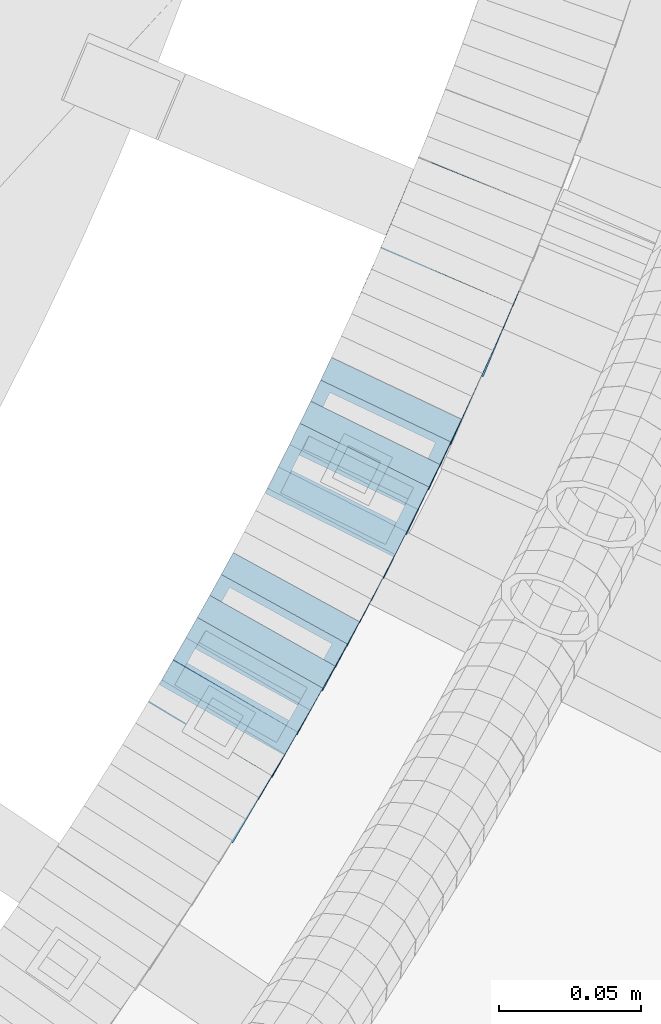
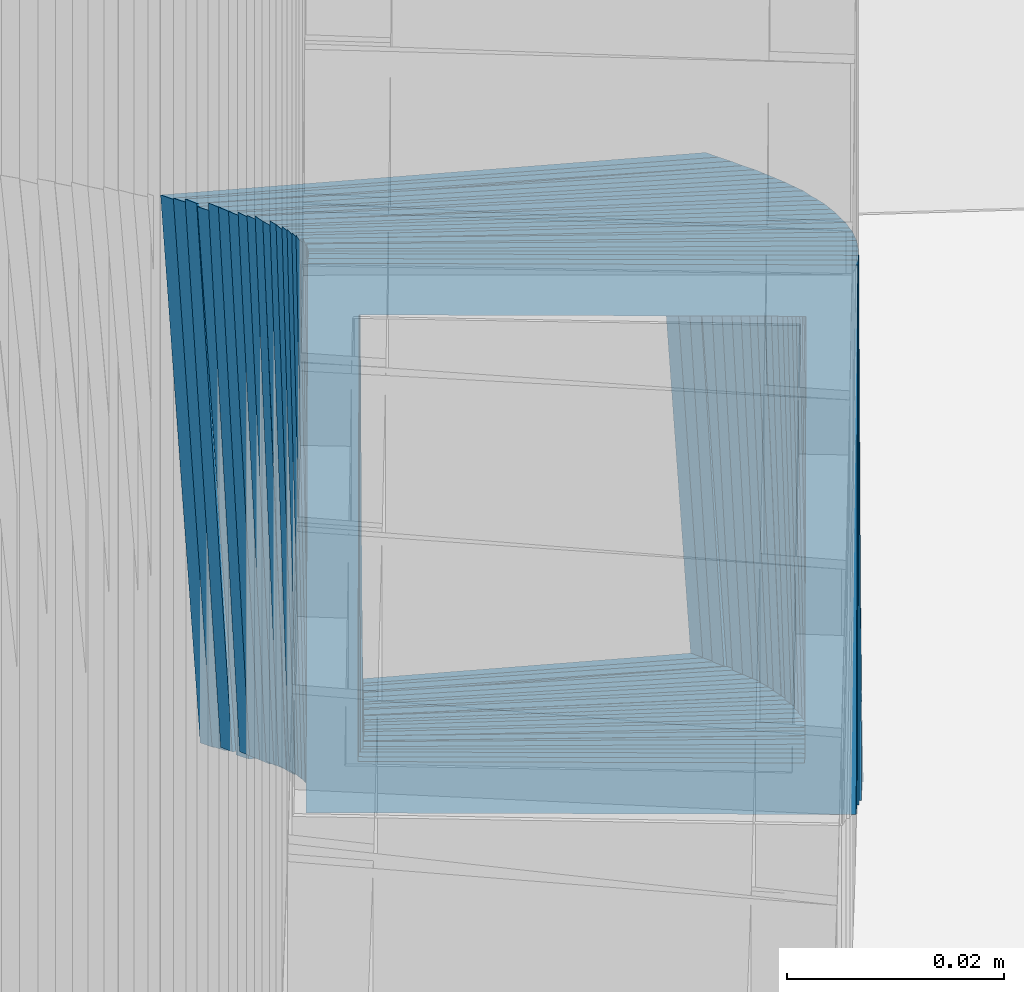
# One storey, part 793 of 975: 25 members.
"""IFC2X3 building model written with IfcOpenShell, lengths in millimetres."""

from ifc_helpers import new_model, si_unit, frame, origin_with_axes, place, context, subcontext, project, spatial, faceted_brep, material, type_object, element, save


model = new_model("IFC2X3")

# Units and contexts
model_context = context("Model", 3, precision=1e-05, world=origin_with_axes())
body_context = subcontext(model_context, "Body", "Model", "MODEL_VIEW")
ifc_project = project(units=[si_unit("LENGTHUNIT", "METRE", prefix="MILLI"), si_unit("AREAUNIT", "SQUARE_METRE"), si_unit("VOLUMEUNIT", "CUBIC_METRE"), si_unit("MASSUNIT", "GRAM", prefix="KILO"), si_unit("TIMEUNIT", "SECOND"), si_unit("PLANEANGLEUNIT", "RADIAN"), si_unit("SOLIDANGLEUNIT", "STERADIAN"), si_unit("THERMODYNAMICTEMPERATUREUNIT", "DEGREE_CELSIUS"), si_unit("LUMINOUSINTENSITYUNIT", "LUMEN")], contexts=[model_context])

# Site, building, storey
site_placement = place(None, origin_with_axes())
site = spatial("IfcSite", under=ifc_project, at=site_placement, CompositionType="ELEMENT")
building_placement = place(site_placement, origin_with_axes())
building = spatial("IfcBuilding", under=site, at=building_placement, Name="Undefined", CompositionType="ELEMENT")
storey_placement = place(building_placement, origin_with_axes())
storey = spatial("IfcBuildingStorey", under=building, at=storey_placement, Name="Undefined", CompositionType="ELEMENT", Elevation=0.0)

# Members
ifc_material = material()
member_type = type_object("IfcMemberType", Name="HSS2X2X.188_TUBES", PredefinedType="NOTDEFINED")
for number, where, z_axis, x_axis, name in (
    (1, (35930.23380263, 2680.68024459294, 2347.39775448158), (0.863371944049593, -0.504568019426546, 2.19373305299087e-10), (-0.425153095937083, -0.727484185892208, 0.538527254920181), "WALL"),
    (2, (35934.73380263, 2688.38024459295, 2341.69775448158), (0.863371944049593, -0.504568019426546, 2.19373305299087e-10), (-0.425153095937083, -0.727484185892208, 0.538527254920181), "WALL"),
):
    element("IfcMember", number, at=place(storey_placement, frame(where, z_axis=z_axis, x_axis=x_axis)), inside=storey, type_object=member_type, material=ifc_material, Name=name, ObjectType="HSS2X2X.188_TUBES", context=body_context, shape_type="Brep", body=[
        faceted_brep([(0.0, 20.6374999999753, -20.6375000000298), (0.0, -20.6375000000153, -20.6375000000153), (10.5806427026419, -20.6374999999607, -20.6374999999316), (10.5806427026473, 20.6375000000444, -20.6374999999207), (0.0, -20.6374999999825, 20.6375000000335), (10.5806427025509, -20.6375000000207, 20.6374999999643), (0.0, 20.6375000000116, 20.6375000000189), (10.5806427025545, 20.6374999999862, 20.6374999999716), (0.0, 25.3999999999724, -25.4000000000342), (0.0, 25.400000000016, 25.4000000000196), (10.5806427025436, 25.3999999999796, 25.3999999999614), (10.5806427026582, 25.4000000000542, -25.3999999999105), (0.0, -25.399999999976, 25.4000000000378), (10.5806427025418, -25.4000000000287, 25.3999999999542), (0.0, -25.400000000016, -25.4000000000196), (10.5806427026528, -25.3999999999542, -25.3999999999178)], [[[0, 1, 2, 3]], [[1, 4, 5, 2]], [[4, 6, 7, 5]], [[6, 0, 3, 7]], [[8, 9, 10, 11]], [[9, 12, 13, 10]], [[12, 14, 15, 13]], [[14, 8, 11, 15]], [[13, 15, 11, 10], [5, 7, 3, 2]], [[14, 12, 9, 8], [6, 4, 1, 0]]]),
    ])
member_1_placement = place(storey_placement, frame((35939.1910256032, 2695.95352275645, 2335.94601811882), z_axis=(0.866185585981234, -0.499722453606346, 3.44320142176002e-10), x_axis=(-0.420120638944193, -0.728209106903375, 0.541488822928149)))
element("IfcMember", 3, at=member_1_placement, inside=storey, type_object=member_type, material=ifc_material, Name="WALL", ObjectType="HSS2X2X.188_TUBES", context=body_context, shape_type="Brep", body=[
    faceted_brep([(0.0, 20.6374999999753, -20.6375000000298), (0.0, -20.6375000000153, -20.6375000000153), (10.7093417165161, -20.637499999968, -20.6374999999534), (10.709341716436, 20.6374999999898, -20.6375000000116), (0.0, -20.6374999999825, 20.6375000000335), (10.7093417164688, -20.6374999999971, 20.6375000000153), (0.0, 20.6375000000116, 20.6375000000189), (10.7093417163924, 20.6374999999643, 20.6374999999571), (0.0, 25.3999999999724, -25.4000000000342), (0.0, 25.400000000016, 25.4000000000196), (10.7093417163815, 25.3999999999542, 25.3999999999469), (10.7093417164288, 25.3999999999869, -25.4000000000196), (0.0, -25.399999999976, 25.4000000000378), (10.7093417164724, -25.3999999999942, 25.4000000000196), (0.0, -25.400000000016, -25.4000000000196), (10.709341716527, -25.3999999999578, -25.3999999999432)], [[[0, 1, 2, 3]], [[1, 4, 5, 2]], [[4, 6, 7, 5]], [[6, 0, 3, 7]], [[8, 9, 10, 11]], [[9, 12, 13, 10]], [[12, 14, 15, 13]], [[14, 8, 11, 15]], [[13, 15, 11, 10], [5, 7, 3, 2]], [[14, 12, 9, 8], [6, 4, 1, 0]]]),
])
for number, where, z_axis, x_axis, name in (
    (4, (35943.6415043193, 2703.57466785414, 2330.17216906364), (0.870978467909721, -0.491321186636232, -1.73427451954922e-10), (-0.414486115155211, -0.734770841274844, 0.536947922200841), "WALL"),
    (5, (35948.0415043193, 2711.37466785414, 2324.47216906364), (0.870978467909721, -0.491321186636232, -1.73427451954922e-10), (-0.414486115155211, -0.734770841274844, 0.536947922200841), "WALL"),
):
    element("IfcMember", number, at=place(storey_placement, frame(where, z_axis=z_axis, x_axis=x_axis)), inside=storey, type_object=member_type, material=ifc_material, Name=name, ObjectType="HSS2X2X.188_TUBES", context=body_context, shape_type="Brep", body=[
        faceted_brep([(0.0, 20.6374999999753, -20.6375000000298), (0.0, -20.6375000000153, -20.6375000000153), (10.6216759506497, -20.637499999968, -20.6374999999534), (10.6216759506497, 20.6375000000262, -20.6374999999643), (0.0, -20.6374999999825, 20.6375000000335), (10.6216759506169, -20.6374999999935, 20.637500000008), (0.0, 20.6375000000116, 20.6375000000189), (10.6216759506242, 20.6375000000007, 20.6374999999971), (0.0, 25.3999999999724, -25.4000000000342), (0.0, 25.400000000016, 25.4000000000196), (10.6216759506169, 25.3999999999978, 25.3999999999869), (10.6216759506533, 25.4000000000269, -25.3999999999614), (0.0, -25.399999999976, 25.4000000000378), (10.6216759506242, -25.3999999999942, 25.4000000000051), (0.0, -25.400000000016, -25.4000000000196), (10.6216759506569, -25.3999999999614, -25.3999999999432)], [[[0, 1, 2, 3]], [[1, 4, 5, 2]], [[4, 6, 7, 5]], [[6, 0, 3, 7]], [[8, 9, 10, 11]], [[9, 12, 13, 10]], [[12, 14, 15, 13]], [[14, 8, 11, 15]], [[13, 15, 11, 10], [5, 7, 3, 2]], [[14, 12, 9, 8], [6, 4, 1, 0]]]),
    ])
member_2_placement = place(storey_placement, frame((35952.2298004585, 2718.69830621929, 2318.81513601728), z_axis=(0.875741388860291, -0.482780508965563, 2.42835085373372e-11), x_axis=(-0.404563680021608, -0.733859699038874, 0.545690545028908)))
element("IfcMember", 6, at=member_2_placement, inside=storey, type_object=member_type, material=ifc_material, Name="WALL", ObjectType="HSS2X2X.188_TUBES", context=body_context, shape_type="Brep", body=[
    faceted_brep([(0.0, 20.6374999999753, -20.6375000000298), (0.0, -20.6375000000153, -20.6375000000153), (10.6348483769107, -20.637499999988, -20.6374999999825), (10.6348483768415, 20.6374999999734, -20.6375000001026), (0.0, -20.6374999999825, 20.6375000000335), (10.6348483769852, -20.6374999999589, 20.6375000001462), (0.0, 20.6375000000116, 20.6375000000189), (10.6348483769161, 20.6375000000044, 20.6375000000226), (0.0, 25.3999999999724, -25.4000000000342), (0.0, 25.400000000016, 25.4000000000196), (10.6348483769179, 25.4000000000015, 25.4000000000233), (10.6348483768288, 25.3999999999669, -25.4000000001324), (0.0, -25.399999999976, 25.4000000000378), (10.6348483769998, -25.3999999999505, 25.4000000001688), (0.0, -25.400000000016, -25.4000000000196), (10.6348483769107, -25.3999999999887, -25.3999999999833)], [[[0, 1, 2, 3]], [[1, 4, 5, 2]], [[4, 6, 7, 5]], [[6, 0, 3, 7]], [[8, 9, 10, 11]], [[9, 12, 13, 10]], [[12, 14, 15, 13]], [[14, 8, 11, 15]], [[13, 15, 11, 10], [5, 7, 3, 2]], [[14, 12, 9, 8], [6, 4, 1, 0]]]),
])
member_3_placement = place(storey_placement, frame((35956.6114431241, 2726.6464022175, 2313.00596511364), z_axis=(0.875741388860291, -0.482780508965563, 2.42835085373372e-11), x_axis=(-0.406638703138386, -0.737623694251199, 0.539032699183589)))
element("IfcMember", 7, at=member_3_placement, inside=storey, type_object=member_type, material=ifc_material, Name="WALL", ObjectType="HSS2X2X.188_TUBES", context=body_context, shape_type="Brep", body=[
    faceted_brep([(0.0, 20.6374999999753, -20.6375000000298), (0.0, -20.6375000000153, -20.6375000000153), (10.5744976239494, -20.6375000000207, -20.6375000000335), (10.5744976239657, 20.6375000000098, -20.637500000008), (0.0, -20.6374999999825, 20.6375000000335), (10.5744976239639, -20.6375000000244, 20.6374999999753), (0.0, 20.6375000000116, 20.6375000000189), (10.5744976239803, 20.6374999999989, 20.6374999999935), (0.0, 25.3999999999724, -25.4000000000342), (0.0, 25.400000000016, 25.4000000000196), (10.5744976239857, 25.4000000000051, 25.4000000000015), (10.5744976239675, 25.4000000000124, -25.4000000000051), (0.0, -25.399999999976, 25.4000000000378), (10.5744976239639, -25.4000000000287, 25.3999999999724), (0.0, -25.400000000016, -25.4000000000196), (10.5744976239494, -25.4000000000215, -25.4000000000378)], [[[0, 1, 2, 3]], [[1, 4, 5, 2]], [[4, 6, 7, 5]], [[6, 0, 3, 7]], [[8, 9, 10, 11]], [[9, 12, 13, 10]], [[12, 14, 15, 13]], [[14, 8, 11, 15]], [[13, 15, 11, 10], [5, 7, 3, 2]], [[14, 12, 9, 8], [6, 4, 1, 0]]]),
])
member_4_placement = place(storey_placement, frame((35960.7518833568, 2733.99775122053, 2307.28657469151), z_axis=(0.882970965834168, -0.469427601972739, 3.48595676769037e-11), x_axis=(-0.393901973853665, -0.740910855725081, 0.543959868798163)))
element("IfcMember", 8, at=member_4_placement, inside=storey, type_object=member_type, material=ifc_material, Name="WALL", ObjectType="HSS2X2X.188_TUBES", context=body_context, shape_type="Brep", body=[
    faceted_brep([(0.0, 20.6374999999753, -20.6375000000298), (0.0, -20.6375000000153, -20.6375000000153), (10.6625512894789, -20.6374999999625, -20.6374999999389), (10.6625512893879, 20.6374999999789, -20.6375000000371), (0.0, -20.6374999999825, 20.6375000000335), (10.6625512894352, -20.6374999999989, 20.6375000000153), (0.0, 20.6375000000116, 20.6375000000189), (10.6625512893443, 20.6374999999443, 20.6374999999134), (0.0, 25.3999999999724, -25.4000000000342), (0.0, 25.400000000016, 25.4000000000196), (10.6625512893297, 25.3999999999342, 25.3999999998996), (10.6625512893916, 25.399999999976, -25.4000000000415), (0.0, -25.399999999976, 25.4000000000378), (10.6625512894389, -25.399999999996, 25.400000000016), (0.0, -25.400000000016, -25.4000000000196), (10.6625512894971, -25.3999999999523, -25.3999999999214)], [[[0, 1, 2, 3]], [[1, 4, 5, 2]], [[4, 6, 7, 5]], [[6, 0, 3, 7]], [[8, 9, 10, 11]], [[9, 12, 13, 10]], [[12, 14, 15, 13]], [[14, 8, 11, 15]], [[13, 15, 11, 10], [5, 7, 3, 2]], [[14, 12, 9, 8], [6, 4, 1, 0]]]),
])
member_5_placement = place(storey_placement, frame((35965.0766180361, 2742.08165273632, 2301.41747598964), z_axis=(0.8853979028468, -0.464833898973051, 2.98718987323809e-11), x_axis=(-0.393141944957003, -0.748841799918479, 0.533549781941926)))
element("IfcMember", 9, at=member_5_placement, inside=storey, type_object=member_type, material=ifc_material, Name="WALL", ObjectType="HSS2X2X.188_TUBES", context=body_context, shape_type="Brep", body=[
    faceted_brep([(0.0, 20.6374999999753, -20.6375000000298), (0.0, -20.6375000000153, -20.6375000000153), (10.6831643251735, -20.6375000000498, -20.6375000000953), (10.6831643252044, 20.637499999988, -20.6375000000226), (0.0, -20.6374999999825, 20.6375000000335), (10.6831643251935, -20.6375000000135, 20.637499999968), (0.0, 20.6375000000116, 20.6375000000189), (10.6831643252244, 20.6375000000226, 20.6375000000407), (0.0, 25.3999999999724, -25.4000000000342), (0.0, 25.400000000016, 25.4000000000196), (10.6831643252317, 25.4000000000306, 25.4000000000597), (10.6831643252044, 25.3999999999905, -25.4000000000196), (0.0, -25.399999999976, 25.4000000000378), (10.6831643251917, -25.400000000016, 25.3999999999614), (0.0, -25.400000000016, -25.4000000000196), (10.6831643251644, -25.400000000056, -25.4000000001179)], [[[0, 1, 2, 3]], [[1, 4, 5, 2]], [[4, 6, 7, 5]], [[6, 0, 3, 7]], [[8, 9, 10, 11]], [[9, 12, 13, 10]], [[12, 14, 15, 13]], [[14, 8, 11, 15]], [[13, 15, 11, 10], [5, 7, 3, 2]], [[14, 12, 9, 8], [6, 4, 1, 0]]]),
])
member_6_placement = place(storey_placement, frame((35969.0326856148, 2749.56592161552, 2295.81953504741), z_axis=(0.887584423843917, -0.460645080891636, -1.58238435687963e-11), x_axis=(-0.385934704788271, -0.743630284592339, 0.545956411700702)))
element("IfcMember", 10, at=member_6_placement, inside=storey, type_object=member_type, material=ifc_material, Name="WALL", ObjectType="HSS2X2X.188_TUBES", context=body_context, shape_type="Brep", body=[
    faceted_brep([(0.0, 20.6374999999753, -20.6375000000298), (0.0, -20.6375000000153, -20.6375000000153), (10.6216759506497, -20.637499999968, -20.6374999999534), (10.6216759506497, 20.6375000000262, -20.6374999999643), (0.0, -20.6374999999825, 20.6375000000335), (10.6216759506169, -20.6374999999935, 20.637500000008), (0.0, 20.6375000000116, 20.6375000000189), (10.6216759506242, 20.6375000000007, 20.6374999999971), (0.0, 25.3999999999724, -25.4000000000342), (0.0, 25.400000000016, 25.4000000000196), (10.6216759506169, 25.3999999999978, 25.3999999999869), (10.6216759506533, 25.4000000000269, -25.3999999999614), (0.0, -25.399999999976, 25.4000000000378), (10.6216759506242, -25.3999999999942, 25.4000000000051), (0.0, -25.400000000016, -25.4000000000196), (10.6216759506569, -25.3999999999614, -25.3999999999432)], [[[0, 1, 2, 3]], [[1, 4, 5, 2]], [[4, 6, 7, 5]], [[6, 0, 3, 7]], [[8, 9, 10, 11]], [[9, 12, 13, 10]], [[12, 14, 15, 13]], [[14, 8, 11, 15]], [[13, 15, 11, 10], [5, 7, 3, 2]], [[14, 12, 9, 8], [6, 4, 1, 0]]]),
])
member_7_placement = place(storey_placement, frame((35973.2573094648, 2757.65401883647, 2289.94881368742), z_axis=(0.88993325058996, -0.456090790845844, 3.15944816975389e-11), x_axis=(-0.385184587902007, -0.751579683808457, 0.535500524863553)))
element("IfcMember", 11, at=member_7_placement, inside=storey, type_object=member_type, material=ifc_material, Name="WALL", ObjectType="HSS2X2X.188_TUBES", context=body_context, shape_type="Brep", body=[
    faceted_brep([(0.0, 20.6374999999753, -20.6375000000298), (0.0, -20.6375000000153, -20.6375000000153), (10.6395488625676, -20.6374999999771, -20.6374999999716), (10.6395488625531, 20.6374999999916, -20.6375000000189), (0.0, -20.6374999999825, 20.6375000000335), (10.6395488625731, -20.6374999999844, 20.6375000000153), (0.0, 20.6375000000116, 20.6375000000189), (10.6395488625585, 20.6374999999825, 20.637499999968), (0.0, 25.3999999999724, -25.4000000000342), (0.0, 25.400000000016, 25.4000000000196), (10.6395488625567, 25.3999999999778, 25.3999999999614), (10.6395488625494, 25.3999999999887, -25.4000000000233), (0.0, -25.399999999976, 25.4000000000378), (10.6395488625749, -25.3999999999851, 25.400000000016), (0.0, -25.400000000016, -25.4000000000196), (10.6395488625658, -25.399999999976, -25.3999999999687)], [[[0, 1, 2, 3]], [[1, 4, 5, 2]], [[4, 6, 7, 5]], [[6, 0, 3, 7]], [[8, 9, 10, 11]], [[9, 12, 13, 10]], [[12, 14, 15, 13]], [[14, 8, 11, 15]], [[13, 15, 11, 10], [5, 7, 3, 2]], [[14, 12, 9, 8], [6, 4, 1, 0]]]),
])
member_8_placement = place(storey_placement, frame((35977.1940742878, 2765.28227921986, 2284.34233991245), z_axis=(0.892157158245305, -0.451725143191812, 3.88258740713355e-11), x_axis=(-0.379834333210075, -0.750172808414593, 0.541263925299127)))
element("IfcMember", 12, at=member_8_placement, inside=storey, type_object=member_type, material=ifc_material, Name="WALL", ObjectType="HSS2X2X.188_TUBES", context=body_context, shape_type="Brep", body=[
    faceted_brep([(0.0, 20.6374999999753, -20.6375000000298), (0.0, -20.6375000000153, -20.6375000000153), (10.5290075505945, -20.637499999968, -20.6375000000116), (10.5290075505436, 20.6374999999898, -20.637499999998), (0.0, -20.6374999999825, 20.6375000000335), (10.5290075505145, -20.6375000000189, 20.637500000008), (0.0, 20.6375000000116, 20.6375000000189), (10.5290075504672, 20.6374999999462, 20.6375000000198), (0.0, 25.3999999999724, -25.4000000000342), (0.0, 25.400000000016, 25.4000000000196), (10.5290075504563, 25.399999999936, 25.4000000000224), (10.5290075505472, 25.3999999999869, -25.3999999999987), (0.0, -25.399999999976, 25.4000000000378), (10.5290075505072, -25.4000000000196, 25.4000000000106), (0.0, -25.400000000016, -25.4000000000196), (10.5290075506091, -25.3999999999651, -25.4000000000151)], [[[0, 1, 2, 3]], [[1, 4, 5, 2]], [[4, 6, 7, 5]], [[6, 0, 3, 7]], [[8, 9, 10, 11]], [[9, 12, 13, 10]], [[12, 14, 15, 13]], [[14, 8, 11, 15]], [[13, 15, 11, 10], [5, 7, 3, 2]], [[14, 12, 9, 8], [6, 4, 1, 0]]]),
])
member_9_placement = place(storey_placement, frame((35981.1579008821, 2773.00001180308, 2278.66383289615), z_axis=(0.896685758144444, -0.442667653145024, 4.20145624957514e-11), x_axis=(-0.373586527045952, -0.756752195093109, 0.53643193606599)))
element("IfcMember", 13, at=member_9_placement, inside=storey, type_object=member_type, material=ifc_material, Name="WALL", ObjectType="HSS2X2X.188_TUBES", context=body_context, shape_type="Brep", body=[
    faceted_brep([(0.0, 20.6374999999753, -20.6375000000298), (0.0, -20.6375000000153, -20.6375000000153), (10.4393486386925, -20.6375000000044, -20.6375000000189), (10.439348638698, 20.6375000000044, -20.6375000000335), (0.0, -20.6374999999825, 20.6375000000335), (10.4393486386525, -20.6375000000207, 20.637500000088), (0.0, 20.6375000000116, 20.6375000000189), (10.4393486386562, 20.637499999988, 20.6375000000698), (0.0, 25.3999999999724, -25.4000000000342), (0.0, 25.400000000016, 25.4000000000196), (10.4393486386562, 25.3999999999869, 25.4000000000815), (10.4393486387034, 25.4000000000069, -25.4000000000487), (0.0, -25.399999999976, 25.4000000000378), (10.4393486386471, -25.4000000000233, 25.4000000001033), (0.0, -25.400000000016, -25.4000000000196), (10.4393486386944, -25.4000000000033, -25.4000000000233)], [[[0, 1, 2, 3]], [[1, 4, 5, 2]], [[4, 6, 7, 5]], [[6, 0, 3, 7]], [[8, 9, 10, 11]], [[9, 12, 13, 10]], [[12, 14, 15, 13]], [[14, 8, 11, 15]], [[13, 15, 11, 10], [5, 7, 3, 2]], [[14, 12, 9, 8], [6, 4, 1, 0]]]),
])
member_10_placement = place(storey_placement, frame((35984.9817783133, 2780.74581480468, 2273.07411051112), z_axis=(0.896685758144444, -0.442667653145024, 4.20145624957514e-11), x_axis=(-0.37166462392525, -0.752859109848314, 0.543202142890569)))
element("IfcMember", 14, at=member_10_placement, inside=storey, type_object=member_type, material=ifc_material, Name="WALL", ObjectType="HSS2X2X.188_TUBES", context=body_context, shape_type="Brep", body=[
    faceted_brep([(0.0, 20.6374999999753, -20.6375000000298), (0.0, -20.6375000000153, -20.6375000000153), (10.4942841585653, -20.6374999999607, -20.637499999928), (10.4942841584889, 20.637499999988, -20.6375000000371), (0.0, -20.6374999999825, 20.6375000000335), (10.4942841585507, -20.6374999999898, 20.6375000000444), (0.0, 20.6375000000116, 20.6375000000189), (10.4942841584725, 20.6374999999643, 20.6374999999498), (0.0, 25.3999999999724, -25.4000000000342), (0.0, 25.400000000016, 25.4000000000196), (10.4942841584598, 25.3999999999542, 25.3999999999323), (10.4942841584798, 25.3999999999869, -25.4000000000451), (0.0, -25.399999999976, 25.4000000000378), (10.4942841585525, -25.3999999999851, 25.4000000000524), (0.0, -25.400000000016, -25.4000000000196), (10.4942841585726, -25.3999999999542, -25.3999999999251)], [[[0, 1, 2, 3]], [[1, 4, 5, 2]], [[4, 6, 7, 5]], [[6, 0, 3, 7]], [[8, 9, 10, 11]], [[9, 12, 13, 10]], [[12, 14, 15, 13]], [[14, 8, 11, 15]], [[13, 15, 11, 10], [5, 7, 3, 2]], [[14, 12, 9, 8], [6, 4, 1, 0]]]),
])
member_11_placement = place(storey_placement, frame((35988.8240617103, 2788.35529932388, 2267.3411432766), z_axis=(0.90327750431061, -0.429056814660246, -2.83282133750618e-10), x_axis=(-0.360793820101281, -0.759565937213122, 0.541190730151835)))
element("IfcMember", 15, at=member_11_placement, inside=storey, type_object=member_type, material=ifc_material, Name="WALL", ObjectType="HSS2X2X.188_TUBES", context=body_context, shape_type="Brep", body=[
    faceted_brep([(0.0, 20.6374999999753, -20.6375000000298), (0.0, -20.6375000000153, -20.6375000000153), (10.5290075505945, -20.637499999968, -20.6375000000116), (10.5290075505436, 20.6374999999898, -20.637499999998), (0.0, -20.6374999999825, 20.6375000000335), (10.5290075505145, -20.6375000000189, 20.637500000008), (0.0, 20.6375000000116, 20.6375000000189), (10.5290075504672, 20.6374999999462, 20.6375000000198), (0.0, 25.3999999999724, -25.4000000000342), (0.0, 25.400000000016, 25.4000000000196), (10.5290075504563, 25.399999999936, 25.4000000000224), (10.5290075505472, 25.3999999999869, -25.3999999999987), (0.0, -25.399999999976, 25.4000000000378), (10.5290075505072, -25.4000000000196, 25.4000000000106), (0.0, -25.400000000016, -25.4000000000196), (10.5290075506091, -25.3999999999651, -25.4000000000151)], [[[0, 1, 2, 3]], [[1, 4, 5, 2]], [[4, 6, 7, 5]], [[6, 0, 3, 7]], [[8, 9, 10, 11]], [[9, 12, 13, 10]], [[12, 14, 15, 13]], [[14, 8, 11, 15]], [[13, 15, 11, 10], [5, 7, 3, 2]], [[14, 12, 9, 8], [6, 4, 1, 0]]]),
])
member_12_placement = place(storey_placement, frame((35992.6977937089, 2796.51052458406, 2261.63151791994), z_axis=(0.90327750431061, -0.429056814660246, -2.83282133750618e-10), x_axis=(-0.362645611901101, -0.763464445791917, 0.534425111854334)))
element("IfcMember", 16, at=member_12_placement, inside=storey, type_object=member_type, material=ifc_material, Name="WALL", ObjectType="HSS2X2X.188_TUBES", context=body_context, shape_type="Brep", body=[
    faceted_brep([(0.0, 20.6374999999753, -20.6375000000298), (0.0, -20.6375000000153, -20.6375000000153), (10.4780723417789, -20.6375000000025, -20.6374999999862), (10.478072341848, 20.6375000000353, -20.6374999999025), (0.0, -20.6374999999825, 20.6375000000335), (10.4780723417261, -20.6375000000317, 20.637499999928), (0.0, 20.6375000000116, 20.6375000000189), (10.4780723417989, 20.637500000008, 20.6375000000189), (0.0, 25.3999999999724, -25.4000000000342), (0.0, 25.400000000016, 25.4000000000196), (10.4780723418007, 25.4000000000106, 25.4000000000233), (10.4780723418644, 25.4000000000433, -25.3999999998814), (0.0, -25.399999999976, 25.4000000000378), (10.4780723417134, -25.4000000000378, 25.3999999999105), (0.0, -25.400000000016, -25.4000000000196), (10.4780723417698, -25.4000000000051, -25.3999999999905)], [[[0, 1, 2, 3]], [[1, 4, 5, 2]], [[4, 6, 7, 5]], [[6, 0, 3, 7]], [[8, 9, 10, 11]], [[9, 12, 13, 10]], [[12, 14, 15, 13]], [[14, 8, 11, 15]], [[13, 15, 11, 10], [5, 7, 3, 2]], [[14, 12, 9, 8], [6, 4, 1, 0]]]),
])
member_13_placement = place(storey_placement, frame((35996.3215328746, 2804.01742321147, 2256.07127507653), z_axis=(0.907627040767263, -0.419777506386492, 2.90030129690422e-10), x_axis=(-0.352492872785095, -0.762146751535154, 0.543029560668775)))
element("IfcMember", 17, at=member_13_placement, inside=storey, type_object=member_type, material=ifc_material, Name="WALL", ObjectType="HSS2X2X.188_TUBES", context=body_context, shape_type="Brep", body=[
    faceted_brep([(0.0, 20.6374999999753, -20.6375000000298), (0.0, -20.6375000000153, -20.6375000000153), (10.5019045891313, -20.6375000000226, -20.6375000000371), (10.5019045891022, 20.6374999999662, -20.6375000000771), (0.0, -20.6374999999825, 20.6375000000335), (10.5019045891859, -20.6374999999771, 20.6375000000444), (0.0, 20.6375000000116, 20.6375000000189), (10.5019045891568, 20.6375000000098, 20.637500000008), (0.0, 25.3999999999724, -25.4000000000342), (0.0, 25.400000000016, 25.4000000000196), (10.5019045891586, 25.4000000000106, 25.400000000016), (10.5019045890895, 25.399999999956, -25.4000000000851), (0.0, -25.399999999976, 25.4000000000378), (10.501904589195, -25.3999999999669, 25.4000000000597), (0.0, -25.400000000016, -25.4000000000196), (10.5019045891258, -25.4000000000269, -25.4000000000451)], [[[0, 1, 2, 3]], [[1, 4, 5, 2]], [[4, 6, 7, 5]], [[6, 0, 3, 7]], [[8, 9, 10, 11]], [[9, 12, 13, 10]], [[12, 14, 15, 13]], [[14, 8, 11, 15]], [[13, 15, 11, 10], [5, 7, 3, 2]], [[14, 12, 9, 8], [6, 4, 1, 0]]]),
])
member_14_placement = place(storey_placement, frame((36000.0720226147, 2812.07214832834, 2250.30714083712), z_axis=(0.909595755713219, -0.415494357589244, -1.62878222909057e-10), x_axis=(-0.349945365160194, -0.76609661035087, 0.539105022246877)))
element("IfcMember", 18, at=member_14_placement, inside=storey, type_object=member_type, material=ifc_material, Name="WALL", ObjectType="HSS2X2X.188_TUBES", context=body_context, shape_type="Brep", body=[
    faceted_brep([(0.0, 20.6374999999753, -20.6375000000298), (0.0, -20.6375000000153, -20.6375000000153), (10.5744976239494, -20.6375000000207, -20.6375000000335), (10.5744976239657, 20.6375000000098, -20.637500000008), (0.0, -20.6374999999825, 20.6375000000335), (10.5744976239639, -20.6375000000244, 20.6374999999753), (0.0, 20.6375000000116, 20.6375000000189), (10.5744976239803, 20.6374999999989, 20.6374999999935), (0.0, 25.3999999999724, -25.4000000000342), (0.0, 25.400000000016, 25.4000000000196), (10.5744976239857, 25.4000000000051, 25.4000000000015), (10.5744976239675, 25.4000000000124, -25.4000000000051), (0.0, -25.399999999976, 25.4000000000378), (10.5744976239639, -25.4000000000287, 25.3999999999724), (0.0, -25.400000000016, -25.4000000000196), (10.5744976239494, -25.4000000000215, -25.4000000000378)], [[[0, 1, 2, 3]], [[1, 4, 5, 2]], [[4, 6, 7, 5]], [[6, 0, 3, 7]], [[8, 9, 10, 11]], [[9, 12, 13, 10]], [[12, 14, 15, 13]], [[14, 8, 11, 15]], [[13, 15, 11, 10], [5, 7, 3, 2]], [[14, 12, 9, 8], [6, 4, 1, 0]]]),
])
for number, where, z_axis, x_axis, name in (
    (19, (36003.6748066531, 2819.83572372163, 2244.63596609755), (0.913811548748505, -0.406138465764889, -7.2476268542232e-11), (-0.341604565111647, -0.768610272251688, 0.540873895177119), "WALL"),
    (20, (36007.2748066531, 2827.93572372163, 2238.93596609755), (0.913811548748505, -0.406138465764889, -7.2476268542232e-11), (-0.341604565111647, -0.768610272251688, 0.540873895177119), "WALL"),
    (21, (36010.8748066531, 2836.03572372163, 2233.23596609755), (0.913811548748505, -0.406138465764889, -7.2476268542232e-11), (-0.341604565111647, -0.768610272251688, 0.540873895177119), "WALL"),
):
    element("IfcMember", number, at=place(storey_placement, frame(where, z_axis=z_axis, x_axis=x_axis)), inside=storey, type_object=member_type, material=ifc_material, Name=name, ObjectType="HSS2X2X.188_TUBES", context=body_context, shape_type="Brep", body=[
        faceted_brep([(0.0, 20.6374999999753, -20.6375000000298), (0.0, -20.6375000000153, -20.6375000000153), (10.5422957651572, -20.6374999999771, -20.6374999999534), (10.5422957651481, 20.6375000000153, -20.6374999999789), (0.0, -20.6374999999825, 20.6375000000335), (10.5422957651535, -20.6374999999971, 20.6375000000298), (0.0, 20.6375000000116, 20.6375000000189), (10.5422957651444, 20.6374999999971, 20.6375000000044), (0.0, 25.3999999999724, -25.4000000000342), (0.0, 25.400000000016, 25.4000000000196), (10.5422957651426, 25.3999999999924, 25.3999999999905), (10.5422957651463, 25.4000000000178, -25.3999999999833), (0.0, -25.399999999976, 25.4000000000378), (10.5422957651499, -25.3999999999996, 25.4000000000269), (0.0, -25.400000000016, -25.4000000000196), (10.5422957651554, -25.3999999999742, -25.3999999999469)], [[[0, 1, 2, 3]], [[1, 4, 5, 2]], [[4, 6, 7, 5]], [[6, 0, 3, 7]], [[8, 9, 10, 11]], [[9, 12, 13, 10]], [[12, 14, 15, 13]], [[14, 8, 11, 15]], [[13, 15, 11, 10], [5, 7, 3, 2]], [[14, 12, 9, 8], [6, 4, 1, 0]]]),
    ])
member_15_placement = place(storey_placement, frame((36014.3456848836, 2843.52508059332, 2227.52683915836), z_axis=(0.923742113544456, -0.383015022765977, -2.67750692728442e-11), x_axis=(-0.322292979994193, -0.777294833985533, 0.540314700989956)))
element("IfcMember", 22, at=member_15_placement, inside=storey, type_object=member_type, material=ifc_material, Name="WALL", ObjectType="HSS2X2X.188_TUBES", context=body_context, shape_type="Brep", body=[
    faceted_brep([(0.0, 20.6374999999753, -20.6375000000298), (0.0, -20.6375000000153, -20.6375000000153), (10.5531985672587, -20.6374999999916, -20.6375000000007), (10.5531985672878, 20.6375000000062, -20.6374999999789), (0.0, -20.6374999999825, 20.6375000000335), (10.5531985672114, -20.6375000000353, 20.6374999999171), (0.0, 20.6375000000116, 20.6375000000189), (10.5531985672333, 20.6374999999607, 20.6374999999316), (0.0, 25.3999999999724, -25.4000000000342), (0.0, 25.400000000016, 25.4000000000196), (10.5531985672314, 25.399999999956, 25.3999999999251), (10.5531985672933, 25.4000000000106, -25.3999999999724), (0.0, -25.399999999976, 25.4000000000378), (10.5531985672023, -25.4000000000397, 25.3999999999069), (0.0, -25.400000000016, -25.4000000000196), (10.5531985672642, -25.3999999999851, -25.3999999999869)], [[[0, 1, 2, 3]], [[1, 4, 5, 2]], [[4, 6, 7, 5]], [[6, 0, 3, 7]], [[8, 9, 10, 11]], [[9, 12, 13, 10]], [[12, 14, 15, 13]], [[14, 8, 11, 15]], [[13, 15, 11, 10], [5, 7, 3, 2]], [[14, 12, 9, 8], [6, 4, 1, 0]]]),
])
member_16_placement = place(storey_placement, frame((36017.8332981078, 2852.06174535471, 2221.79970631529), z_axis=(0.919724178958897, -0.392565197946001, -2.1436790120788e-11), x_axis=(-0.330748445965462, -0.774896359918556, 0.538647469943379)))
element("IfcMember", 23, at=member_16_placement, inside=storey, type_object=member_type, material=ifc_material, Name="WALL", ObjectType="HSS2X2X.188_TUBES", context=body_context, shape_type="Brep", body=[
    faceted_brep([(0.0, 20.6374999999753, -20.6375000000298), (0.0, -20.6375000000153, -20.6375000000153), (10.5806427026419, -20.6374999999607, -20.6374999999316), (10.5806427026473, 20.6375000000444, -20.6374999999207), (0.0, -20.6374999999825, 20.6375000000335), (10.5806427025509, -20.6375000000207, 20.6374999999643), (0.0, 20.6375000000116, 20.6375000000189), (10.5806427025545, 20.6374999999862, 20.6374999999716), (0.0, 25.3999999999724, -25.4000000000342), (0.0, 25.400000000016, 25.4000000000196), (10.5806427025436, 25.3999999999796, 25.3999999999614), (10.5806427026582, 25.4000000000542, -25.3999999999105), (0.0, -25.399999999976, 25.4000000000378), (10.5806427025418, -25.4000000000287, 25.3999999999542), (0.0, -25.400000000016, -25.4000000000196), (10.5806427026528, -25.3999999999542, -25.3999999999178)], [[[0, 1, 2, 3]], [[1, 4, 5, 2]], [[4, 6, 7, 5]], [[6, 0, 3, 7]], [[8, 9, 10, 11]], [[9, 12, 13, 10]], [[12, 14, 15, 13]], [[14, 8, 11, 15]], [[13, 15, 11, 10], [5, 7, 3, 2]], [[14, 12, 9, 8], [6, 4, 1, 0]]]),
])
member_17_placement = place(storey_placement, frame((36021.2456848836, 2859.92508059332, 2216.12683915836), z_axis=(0.923742113544456, -0.383015022765977, -2.67750692728442e-11), x_axis=(-0.322292979994193, -0.777294833985533, 0.540314700989956)))
element("IfcMember", 24, at=member_17_placement, inside=storey, type_object=member_type, material=ifc_material, Name="WALL", ObjectType="HSS2X2X.188_TUBES", context=body_context, shape_type="Brep", body=[
    faceted_brep([(0.0, 20.6374999999753, -20.6375000000298), (0.0, -20.6375000000153, -20.6375000000153), (10.5531985672587, -20.6374999999916, -20.6375000000007), (10.5531985672878, 20.6375000000062, -20.6374999999789), (0.0, -20.6374999999825, 20.6375000000335), (10.5531985672114, -20.6375000000353, 20.6374999999171), (0.0, 20.6375000000116, 20.6375000000189), (10.5531985672333, 20.6374999999607, 20.6374999999316), (0.0, 25.3999999999724, -25.4000000000342), (0.0, 25.400000000016, 25.4000000000196), (10.5531985672314, 25.399999999956, 25.3999999999251), (10.5531985672933, 25.4000000000106, -25.3999999999724), (0.0, -25.399999999976, 25.4000000000378), (10.5531985672023, -25.4000000000397, 25.3999999999069), (0.0, -25.400000000016, -25.4000000000196), (10.5531985672642, -25.3999999999851, -25.3999999999869)], [[[0, 1, 2, 3]], [[1, 4, 5, 2]], [[4, 6, 7, 5]], [[6, 0, 3, 7]], [[8, 9, 10, 11]], [[9, 12, 13, 10]], [[12, 14, 15, 13]], [[14, 8, 11, 15]], [[13, 15, 11, 10], [5, 7, 3, 2]], [[14, 12, 9, 8], [6, 4, 1, 0]]]),
])
member_18_placement = place(storey_placement, frame((36024.6966805221, 2868.19557806829, 2210.36256359731), z_axis=(0.925369259230161, -0.379066925584154, 2.88076535071014e-10), x_axis=(-0.319930043879899, -0.781005694706487, 0.536353308798449)))
element("IfcMember", 25, at=member_18_placement, inside=storey, type_object=member_type, material=ifc_material, Name="WALL", ObjectType="HSS2X2X.188_TUBES", context=body_context, shape_type="Brep", body=[
    faceted_brep([(0.0, 20.6374999999753, -20.6375000000298), (0.0, -20.6375000000153, -20.6375000000153), (10.6348483769107, -20.637499999988, -20.6374999999825), (10.6348483768415, 20.6374999999734, -20.6375000001026), (0.0, -20.6374999999825, 20.6375000000335), (10.6348483769852, -20.6374999999589, 20.6375000001462), (0.0, 20.6375000000116, 20.6375000000189), (10.6348483769161, 20.6375000000044, 20.6375000000226), (0.0, 25.3999999999724, -25.4000000000342), (0.0, 25.400000000016, 25.4000000000196), (10.6348483769179, 25.4000000000015, 25.4000000000233), (10.6348483768288, 25.3999999999669, -25.4000000001324), (0.0, -25.399999999976, 25.4000000000378), (10.6348483769998, -25.3999999999505, 25.4000000001688), (0.0, -25.400000000016, -25.4000000000196), (10.6348483769107, -25.3999999999887, -25.3999999999833)], [[[0, 1, 2, 3]], [[1, 4, 5, 2]], [[4, 6, 7, 5]], [[6, 0, 3, 7]], [[8, 9, 10, 11]], [[9, 12, 13, 10]], [[12, 14, 15, 13]], [[14, 8, 11, 15]], [[13, 15, 11, 10], [5, 7, 3, 2]], [[14, 12, 9, 8], [6, 4, 1, 0]]]),
])

save(model, "model.ifc")
